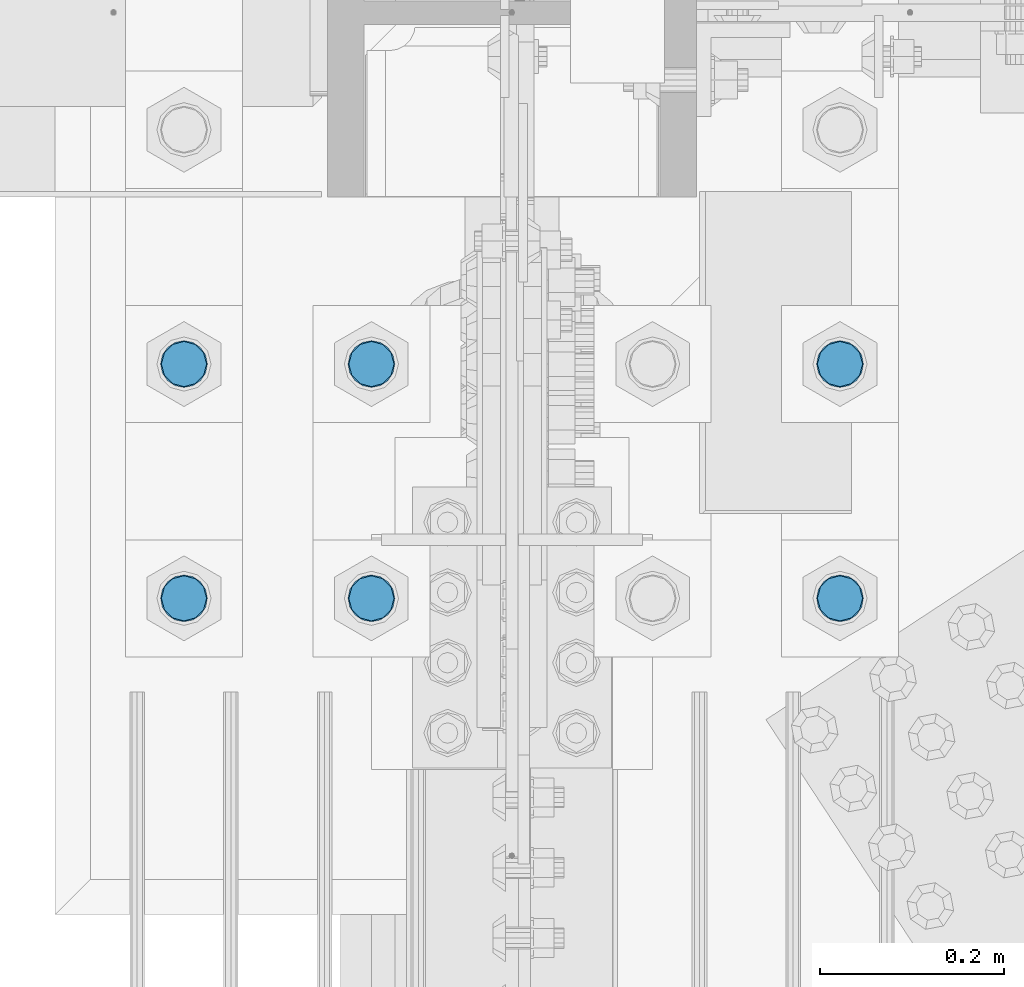
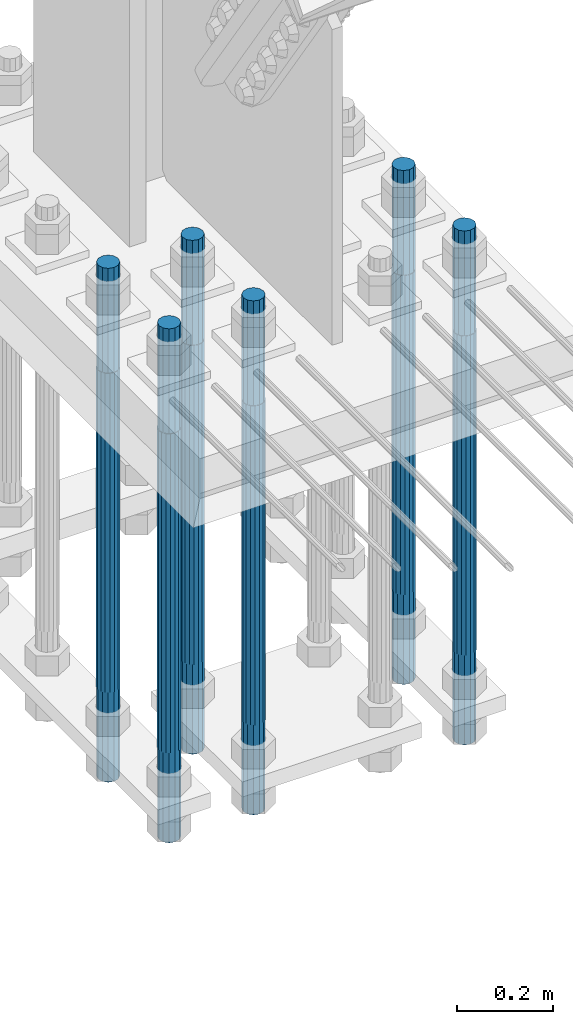
# One storey, part 1329 of 3843: 6 columns, 1 element without a shape of its own.
"""IFC2X3 building model written with IfcOpenShell, lengths in millimetres."""

import ifcopenshell
import ifcopenshell.guid

model = None  # the IFC model being written
_history = None  # IfcOwnerHistory: only IFC2X3 demands one
_inside = {}  # id of a spatial element -> (the spatial element, [elements in it])
_under = {}  # id of a project, library or spatial element -> (it, [spatial elements below it])
_declared = {}  # id of a project -> (the project, [libraries it declares])
_typed = {}  # id of a type object -> (the type object, [elements of that type])
_made_of = {}  # id of a material, layer set ... -> (it, [elements and type objects made of it])


def new_model(schema):
    """Start an empty IFC model of exactly this schema.

    Asked for "IFC4X3", IfcOpenShell would pick the latest addendum, in which some entities
    have other attributes; the version numbers below select the first issue.
    IFC2X3 requires an IfcOwnerHistory on every rooted entity: one is made here for all.
    """
    global model, _history
    if schema == "IFC4X3":
        model = ifcopenshell.file(schema_version=(4, 3, 0, 0))
    else:
        model = ifcopenshell.file(schema=schema)
    _inside.clear()
    _under.clear()
    _declared.clear()
    _typed.clear()
    _made_of.clear()
    _history = None
    if model.schema == "IFC2X3":
        org = make("IfcOrganization", Name="unknown")
        user = make(
            "IfcPersonAndOrganization",
            ThePerson=make("IfcPerson", FamilyName="unknown"),
            TheOrganization=org,
        )
        app = make(
            "IfcApplication",
            ApplicationDeveloper=org,
            Version="unknown",
            ApplicationFullName="unknown",
            ApplicationIdentifier="unknown",
        )
        _history = make(
            "IfcOwnerHistory",
            OwningUser=user,
            OwningApplication=app,
            ChangeAction="ADDED",
            CreationDate=0,
        )
    return model


def make(cls, **values):
    """One entity of the class cls with the attributes given. An attribute that is None is left unset."""
    return model.create_entity(
        cls, **{name: value for name, value in values.items() if value is not None}
    )


def rooted(cls, **values):
    """An entity with a GlobalId (a new one), such as an element, a storey or a relation."""
    return make(cls, GlobalId=ifcopenshell.guid.new(), OwnerHistory=_history, **values)


def si_unit(unit_type, name, prefix=None):
    """IfcSIUnit, for example si_unit("LENGTHUNIT", "METRE", prefix="MILLI")."""
    return make("IfcSIUnit", UnitType=unit_type, Prefix=prefix, Name=name)


def assignment(units):
    """IfcUnitAssignment: the units of a project."""
    return None if units is None else make("IfcUnitAssignment", Units=units)


def point(xyz):
    """IfcCartesianPoint."""
    return None if xyz is None else make("IfcCartesianPoint", Coordinates=xyz)


def direction(xyz):
    """IfcDirection."""
    return None if xyz is None else make("IfcDirection", DirectionRatios=xyz)


def frame(location, z_axis=None, x_axis=None):
    """IfcAxis2Placement3D, a coordinate frame: its origin and axes. An axis left out is left unset."""
    return make(
        "IfcAxis2Placement3D",
        Location=point(location),
        Axis=direction(z_axis),
        RefDirection=direction(x_axis),
    )


def origin_with_axes():
    """The frame at (0, 0, 0) with the z axis (0, 0, 1) and the x axis (1, 0, 0) written out."""
    return frame((0.0, 0.0, 0.0), z_axis=(0.0, 0.0, 1.0), x_axis=(1.0, 0.0, 0.0))


def place(relative_to, where):
    """IfcLocalPlacement: puts the frame where relative to a parent placement (None: the world)."""
    return make(
        "IfcLocalPlacement", PlacementRelTo=relative_to, RelativePlacement=where
    )


def context(
    kind, dimensions, precision=None, world=None, true_north=None, identifier=None
):
    """IfcGeometricRepresentationContext, for example the 3D "Model" context."""
    return make(
        "IfcGeometricRepresentationContext",
        ContextIdentifier=identifier,
        ContextType=kind,
        CoordinateSpaceDimension=dimensions,
        Precision=precision,
        WorldCoordinateSystem=world,
        TrueNorth=true_north,
    )


def subcontext(parent, identifier, kind, view, scale=None):
    """IfcGeometricRepresentationSubContext, for example "Body" below "Model"."""
    return make(
        "IfcGeometricRepresentationSubContext",
        ContextIdentifier=identifier,
        ContextType=kind,
        ParentContext=parent,
        TargetScale=scale,
        TargetView=view,
    )


def project(units=None, contexts=None):
    """IfcProject with its units and contexts."""
    return rooted(
        "IfcProject",
        Name="project",
        RepresentationContexts=contexts,
        UnitsInContext=assignment(units),
    )


def spatial(cls, under=None, at=None, **own):
    """A site, building, storey or space (cls), placed at a placement, below another one or the project."""
    s = rooted(cls, ObjectPlacement=at, **own)
    if under is not None:
        _under.setdefault(under.id(), (under, []))[1].append(s)
    return s


def faces_of(points, faces, orient=None, outer=None):
    """IfcFace entities. A face is a list of loops; a loop is a list of indices into points, from 0.

    orient and outer hold one flag for each loop. By default every Orientation is true, the
    first loop of a face is its IfcFaceOuterBound and the others are IfcFaceBound.
    """
    made = []
    for i, loops in enumerate(faces):
        bounds = []
        for j, loop in enumerate(loops):
            is_outer = j == 0 if outer is None else outer[i][j]
            bounds.append(
                make(
                    "IfcFaceOuterBound" if is_outer else "IfcFaceBound",
                    Bound=make("IfcPolyLoop", Polygon=[points[k] for k in loop]),
                    Orientation=True if orient is None else orient[i][j],
                )
            )
        made.append(make("IfcFace", Bounds=bounds))
    return made


def faceted_brep(points, faces, orient=None, outer=None, voids=None):
    """IfcFacetedBrep: a solid bounded by flat faces; with voids (closed shells), ...WithVoids."""
    shared = [point(p) for p in points]
    hull = make("IfcClosedShell", CfsFaces=faces_of(shared, faces, orient, outer))
    if voids is None:
        return make("IfcFacetedBrep", Outer=hull)
    return make(
        "IfcFacetedBrepWithVoids",
        Outer=hull,
        Voids=[
            make(cls, CfsFaces=faces_of(shared, fs, o, b)) for cls, fs, o, b in voids
        ],
    )


def shape(context_of_items, identifier, shape_type, items):
    """IfcShapeRepresentation: the items that make up one representation, for example the "Body"."""
    return make(
        "IfcShapeRepresentation",
        ContextOfItems=context_of_items,
        RepresentationIdentifier=identifier,
        RepresentationType=shape_type,
        Items=items,
    )


def material(Name=None, Category=None):
    """IfcMaterial."""
    return make("IfcMaterial", Name=Name, Category=Category)


def made_of(thing, what):
    """Note that an element or type object is made of a material, layer set ...; save() writes the relation."""
    if what is not None:
        _made_of.setdefault(what.id(), (what, []))[1].append(thing)
    return thing


def type_object(cls, material=None, **own):
    """A type object (cls), such as IfcWallType, which elements share."""
    return made_of(rooted(cls, **own), material)


def element(
    cls,
    number,
    at=None,
    inside=None,
    cuts=None,
    type_object=None,
    material=None,
    context=None,
    identifier="Body",
    shape_type=None,
    held_by="IfcProductDefinitionShape",
    body=None,
    shapes=None,
    **own,
):
    """One element of the class cls, such as IfcWall. Its Tag is "e" and its number.

    at: its placement. inside: the storey or other place that contains it. cuts: it is an
    opening in that element (IfcRelVoidsElement). A single representation is given by context,
    identifier, shape_type and body (its items); several are given by shapes. held_by: the class
    of the entity that holds the representations. save() writes the other relations.
    """
    e = rooted(cls, Tag="e%d" % number, ObjectPlacement=at, **own)
    if body is not None:
        shapes = [shape(context, identifier, shape_type, body)]
    if shapes is not None:
        e.Representation = make(held_by, Representations=shapes)
    if inside is not None:
        _inside.setdefault(inside.id(), (inside, []))[1].append(e)
    if cuts is not None:
        rooted(
            "IfcRelVoidsElement", RelatingBuildingElement=cuts, RelatedOpeningElement=e
        )
    if type_object is not None:
        _typed.setdefault(type_object.id(), (type_object, []))[1].append(e)
    return made_of(e, material)


def aggregate(whole, parts):
    """IfcRelAggregates: a whole, such as a stair, and the parts it consists of."""
    return rooted("IfcRelAggregates", RelatingObject=whole, RelatedObjects=parts)


def save(model, path):
    """Write the relations noted so far, then the file.

    IfcRelAggregates (storeys below a building ...), IfcRelContainedInSpatialStructure (elements
    in a storey), IfcRelDefinesByType, IfcRelAssociatesMaterial and IfcRelDeclares: one each for
    every whole, place, type object, material and project.
    """
    for whole, parts in _under.values():
        aggregate(whole, parts)
    for where, things in _inside.values():
        rooted(
            "IfcRelContainedInSpatialStructure",
            RelatedElements=things,
            RelatingStructure=where,
        )
    for kind, things in _typed.values():
        rooted("IfcRelDefinesByType", RelatedObjects=things, RelatingType=kind)
    for what, things in _made_of.values():
        rooted("IfcRelAssociatesMaterial", RelatedObjects=things, RelatingMaterial=what)
    for by, libraries in _declared.values():
        rooted("IfcRelDeclares", RelatingContext=by, RelatedDefinitions=libraries)
    model.write(path)


model = new_model("IFC2X3")

# Units and contexts
model_context = context("Model", 3, precision=1e-05, world=origin_with_axes())
body_context = subcontext(model_context, "Body", "Model", "MODEL_VIEW")
ifc_project = project(units=[si_unit("LENGTHUNIT", "METRE", prefix="MILLI"), si_unit("AREAUNIT", "SQUARE_METRE"), si_unit("VOLUMEUNIT", "CUBIC_METRE"), si_unit("MASSUNIT", "GRAM", prefix="KILO"), si_unit("TIMEUNIT", "SECOND"), si_unit("PLANEANGLEUNIT", "RADIAN"), si_unit("SOLIDANGLEUNIT", "STERADIAN"), si_unit("THERMODYNAMICTEMPERATUREUNIT", "DEGREE_CELSIUS"), si_unit("LUMINOUSINTENSITYUNIT", "LUMEN")], contexts=[model_context])

# Site, building, storey
site_placement = place(None, origin_with_axes())
site = spatial("IfcSite", under=ifc_project, at=site_placement, CompositionType="ELEMENT")
building_placement = place(site_placement, origin_with_axes())
building = spatial("IfcBuilding", under=site, at=building_placement, Name="Undefined", CompositionType="ELEMENT")
storey_placement = place(building_placement, origin_with_axes())
storey = spatial("IfcBuildingStorey", under=building, at=storey_placement, Name="Undefined", CompositionType="ELEMENT", Elevation=0.0)

# Assembly, columns
assembly_placement = place(storey_placement, origin_with_axes())
assembly = element("IfcElementAssembly", 1, at=assembly_placement, inside=storey, Name="TEMPLATE", AssemblyPlace="NOTDEFINED", PredefinedType="RIGID_FRAME")
ifc_material = material(Name="Undefined/F1554-GR.55")
column_type = type_object("IfcColumnType", PredefinedType="NOTDEFINED")
column_1_placement = place(assembly_placement, frame((36931.6, 58280.3, 30022.8), z_axis=(1.0, 0.0, 0.0), x_axis=(0.0, 0.0, -1.0)))
column_1 = element("IfcColumn", 2, at=column_1_placement, type_object=column_type, material=ifc_material, Name="ANCHOR_ROD", context=body_context, shape_type="Brep", body=[
    faceted_brep([(-266.700000000001, -21.2176223927236, 12.25), (-266.700000000001, -12.25, 21.2176223927163), (-266.700000000001, 0.0, 24.5), (-266.700000000001, 12.25, 21.2176223927163), (-266.700000000001, 21.2176223927236, 12.25), (-266.700000000001, 24.5, 0.0), (-266.700000000001, 21.2176223927236, -12.25), (-266.700000000001, 12.25, -21.2176223927163), (-266.700000000001, 0.0, -24.5), (-266.700000000001, -12.25, -21.2176223927163), (-266.700000000001, -21.2176223927236, -12.25), (-266.700000000001, -24.5, 0.0), (0.0, 24.5000000000146, 0.0), (0.0, 21.2176223927381, -12.25), (0.0, 12.2500000000146, -21.2176223927163), (0.0, 1.45519152283669e-11, -24.5), (0.0, -12.2499999999854, -21.2176223927163), (0.0, -21.217622392709, -12.25), (0.0, -24.4999999999854, 0.0), (0.0, -21.217622392709, 12.25), (0.0, -12.2499999999854, 21.2176223927163), (0.0, 1.45519152283669e-11, 24.5), (0.0, 12.2500000000146, 21.2176223927163), (0.0, 21.2176223927381, 12.25), (0.0, -23.4665401257807, 9.72015918207035), (0.0, -17.9605122421344, 17.9605122421417), (0.0, -9.72015918207762, 23.466540125788), (0.0, 0.0, 25.4000000000015), (0.0, 9.72015918207762, 23.466540125788), (0.0, 17.9605122421344, 17.9605122421417), (0.0, 23.4665401257807, 9.72015918207035), (0.0, 25.3999996185303, 0.0), (0.0, 23.4665401257807, -9.72015918207035), (0.0, 17.9605122421344, -17.9605122421417), (0.0, 9.72015918207762, -23.466540125788), (0.0, 0.0, -25.4000000000015), (0.0, -9.72015918207762, -23.466540125788), (0.0, -17.9605122421344, -17.9605122421417), (0.0, -23.4665401257807, -9.72015918207035), (0.0, -25.3999996185303, 0.0), (812.799999999999, -25.4000000000015, 0.0), (812.799999999999, -23.466540125788, 9.72015918207398), (812.799999999999, -17.9605122421417, 17.9605122421381), (812.799999999999, -9.72015918207035, 23.466540125788), (812.799999999999, 0.0, 25.4000000000015), (812.799999999999, 9.72015918207035, 23.466540125788), (812.799999999999, 17.9605122421417, 17.9605122421381), (812.799999999999, 23.466540125788, 9.72015918207398), (812.799999999999, 25.4000000000015, 0.0), (812.799999999999, 23.466540125788, -9.72015918207398), (812.799999999999, 17.9605122421417, -17.9605122421381), (812.799999999999, 9.72015918207035, -23.466540125788), (812.799999999999, 0.0, -25.4000000000015), (812.799999999999, -9.72015918207035, -23.466540125788), (812.799999999999, -17.9605122421417, -17.9605122421381), (812.799999999999, -23.466540125788, -9.72015918207398), (812.799999999999, -12.25, 21.2176223927199), (812.799999999999, 0.0, 24.5), (812.799999999999, 12.25, 21.2176223927199), (812.799999999999, 21.2176223927163, 12.25), (812.799999999999, 24.5, 0.0), (812.799999999999, 21.2176223927163, -12.25), (812.799999999999, 12.25, -21.2176223927199), (812.799999999999, 0.0, -24.5), (812.799999999999, -12.25, -21.2176223927199), (812.799999999999, -21.2176223927163, -12.25), (812.799999999999, -24.5, 0.0), (812.799999999999, -21.2176223927163, 12.25), (1041.4, -12.25, -21.2176223927199), (1041.4, 0.0, -24.5), (1041.4, 12.25, -21.2176223927199), (1041.4, 21.2176223927163, -12.25), (1041.4, 24.5, 0.0), (1041.4, 21.2176223927163, 12.25), (1041.4, 12.25, 21.2176223927199), (1041.4, 0.0, 24.5), (1041.4, -12.25, 21.2176223927199), (1041.4, -21.2176223927163, 12.25), (1041.4, -24.5, 0.0), (1041.4, -21.2176223927163, -12.25)], [[[0, 1, 2, 3, 4, 5, 6, 7, 8, 9, 10, 11]], [[6, 5, 12, 13]], [[7, 6, 13, 14]], [[8, 7, 14, 15]], [[9, 8, 15, 16]], [[10, 9, 16, 17]], [[11, 10, 17, 18]], [[0, 11, 18, 19]], [[1, 0, 19, 20]], [[2, 1, 20, 21]], [[3, 2, 21, 22]], [[4, 3, 22, 23]], [[5, 4, 23, 12]], [[24, 25, 26, 27, 28, 29, 30, 31, 32, 33, 34, 35, 36, 37, 38, 39], [22, 21, 20, 19, 18, 17, 16, 15, 14, 13, 12, 23]], [[24, 39, 40, 41]], [[25, 24, 41, 42]], [[26, 25, 42, 43]], [[27, 26, 43, 44]], [[28, 27, 44, 45]], [[29, 28, 45, 46]], [[30, 29, 46, 47]], [[31, 30, 47, 48]], [[32, 31, 48, 49]], [[33, 32, 49, 50]], [[34, 33, 50, 51]], [[35, 34, 51, 52]], [[36, 35, 52, 53]], [[37, 36, 53, 54]], [[38, 37, 54, 55]], [[39, 38, 55, 40]], [[54, 53, 52, 51, 50, 49, 48, 47, 46, 45, 44, 43, 42, 41, 40, 55], [56, 57, 58, 59, 60, 61, 62, 63, 64, 65, 66, 67]], [[68, 69, 70, 71, 72, 73, 74, 75, 76, 77, 78, 79]], [[76, 75, 57, 56]], [[77, 76, 56, 67]], [[78, 77, 67, 66]], [[79, 78, 66, 65]], [[68, 79, 65, 64]], [[69, 68, 64, 63]], [[70, 69, 63, 62]], [[71, 70, 62, 61]], [[72, 71, 61, 60]], [[73, 72, 60, 59]], [[74, 73, 59, 58]], [[75, 74, 58, 57]]]),
])
column_2_placement = place(assembly_placement, frame((36931.6, 58534.3, 30022.8), z_axis=(1.0, 0.0, 0.0), x_axis=(0.0, 0.0, -1.0)))
column_2 = element("IfcColumn", 3, at=column_2_placement, type_object=column_type, material=ifc_material, Name="ANCHOR_ROD", context=body_context, shape_type="Brep", body=[
    faceted_brep([(-266.700000000001, -21.2176223927236, 12.25), (-266.700000000001, -12.25, 21.2176223927163), (-266.700000000001, 0.0, 24.5), (-266.700000000001, 12.25, 21.2176223927163), (-266.700000000001, 21.2176223927236, 12.25), (-266.700000000001, 24.5, 0.0), (-266.700000000001, 21.2176223927236, -12.25), (-266.700000000001, 12.25, -21.2176223927163), (-266.700000000001, 0.0, -24.5), (-266.700000000001, -12.25, -21.2176223927163), (-266.700000000001, -21.2176223927236, -12.25), (-266.700000000001, -24.5, 0.0), (0.0, 24.5000000000146, 0.0), (0.0, 21.2176223927381, -12.25), (0.0, 12.2500000000146, -21.2176223927163), (0.0, 1.45519152283669e-11, -24.5), (0.0, -12.2499999999854, -21.2176223927163), (0.0, -21.217622392709, -12.25), (0.0, -24.4999999999854, 0.0), (0.0, -21.217622392709, 12.25), (0.0, -12.2499999999854, 21.2176223927163), (0.0, 1.45519152283669e-11, 24.5), (0.0, 12.2500000000146, 21.2176223927163), (0.0, 21.2176223927381, 12.25), (0.0, -23.4665401257807, 9.72015918207035), (0.0, -17.9605122421344, 17.9605122421417), (0.0, -9.72015918207762, 23.466540125788), (0.0, 0.0, 25.4000000000015), (0.0, 9.72015918207762, 23.466540125788), (0.0, 17.9605122421344, 17.9605122421417), (0.0, 23.4665401257807, 9.72015918207035), (0.0, 25.3999996185303, 0.0), (0.0, 23.4665401257807, -9.72015918207035), (0.0, 17.9605122421344, -17.9605122421417), (0.0, 9.72015918207762, -23.466540125788), (0.0, 0.0, -25.4000000000015), (0.0, -9.72015918207762, -23.466540125788), (0.0, -17.9605122421344, -17.9605122421417), (0.0, -23.4665401257807, -9.72015918207035), (0.0, -25.3999996185303, 0.0), (812.799999999999, -25.4000000000015, 0.0), (812.799999999999, -23.466540125788, 9.72015918207398), (812.799999999999, -17.9605122421417, 17.9605122421381), (812.799999999999, -9.72015918207035, 23.466540125788), (812.799999999999, 0.0, 25.4000000000015), (812.799999999999, 9.72015918207035, 23.466540125788), (812.799999999999, 17.9605122421417, 17.9605122421381), (812.799999999999, 23.466540125788, 9.72015918207398), (812.799999999999, 25.4000000000015, 0.0), (812.799999999999, 23.466540125788, -9.72015918207398), (812.799999999999, 17.9605122421417, -17.9605122421381), (812.799999999999, 9.72015918207035, -23.466540125788), (812.799999999999, 0.0, -25.4000000000015), (812.799999999999, -9.72015918207035, -23.466540125788), (812.799999999999, -17.9605122421417, -17.9605122421381), (812.799999999999, -23.466540125788, -9.72015918207398), (812.799999999999, -12.25, 21.2176223927199), (812.799999999999, 0.0, 24.5), (812.799999999999, 12.25, 21.2176223927199), (812.799999999999, 21.2176223927163, 12.25), (812.799999999999, 24.5, 0.0), (812.799999999999, 21.2176223927163, -12.25), (812.799999999999, 12.25, -21.2176223927199), (812.799999999999, 0.0, -24.5), (812.799999999999, -12.25, -21.2176223927199), (812.799999999999, -21.2176223927163, -12.25), (812.799999999999, -24.5, 0.0), (812.799999999999, -21.2176223927163, 12.25), (1041.4, -12.25, -21.2176223927199), (1041.4, 0.0, -24.5), (1041.4, 12.25, -21.2176223927199), (1041.4, 21.2176223927163, -12.25), (1041.4, 24.5, 0.0), (1041.4, 21.2176223927163, 12.25), (1041.4, 12.25, 21.2176223927199), (1041.4, 0.0, 24.5), (1041.4, -12.25, 21.2176223927199), (1041.4, -21.2176223927163, 12.25), (1041.4, -24.5, 0.0), (1041.4, -21.2176223927163, -12.25)], [[[0, 1, 2, 3, 4, 5, 6, 7, 8, 9, 10, 11]], [[6, 5, 12, 13]], [[7, 6, 13, 14]], [[8, 7, 14, 15]], [[9, 8, 15, 16]], [[10, 9, 16, 17]], [[11, 10, 17, 18]], [[0, 11, 18, 19]], [[1, 0, 19, 20]], [[2, 1, 20, 21]], [[3, 2, 21, 22]], [[4, 3, 22, 23]], [[5, 4, 23, 12]], [[24, 25, 26, 27, 28, 29, 30, 31, 32, 33, 34, 35, 36, 37, 38, 39], [22, 21, 20, 19, 18, 17, 16, 15, 14, 13, 12, 23]], [[24, 39, 40, 41]], [[25, 24, 41, 42]], [[26, 25, 42, 43]], [[27, 26, 43, 44]], [[28, 27, 44, 45]], [[29, 28, 45, 46]], [[30, 29, 46, 47]], [[31, 30, 47, 48]], [[32, 31, 48, 49]], [[33, 32, 49, 50]], [[34, 33, 50, 51]], [[35, 34, 51, 52]], [[36, 35, 52, 53]], [[37, 36, 53, 54]], [[38, 37, 54, 55]], [[39, 38, 55, 40]], [[54, 53, 52, 51, 50, 49, 48, 47, 46, 45, 44, 43, 42, 41, 40, 55], [56, 57, 58, 59, 60, 61, 62, 63, 64, 65, 66, 67]], [[68, 69, 70, 71, 72, 73, 74, 75, 76, 77, 78, 79]], [[76, 75, 57, 56]], [[77, 76, 56, 67]], [[78, 77, 67, 66]], [[79, 78, 66, 65]], [[68, 79, 65, 64]], [[69, 68, 64, 63]], [[70, 69, 63, 62]], [[71, 70, 62, 61]], [[72, 71, 61, 60]], [[73, 72, 60, 59]], [[74, 73, 59, 58]], [[75, 74, 58, 57]]]),
])
column_3_placement = place(assembly_placement, frame((36423.6, 58280.3, 30022.8), z_axis=(1.0, 0.0, 0.0), x_axis=(0.0, 0.0, -1.0)))
column_3 = element("IfcColumn", 4, at=column_3_placement, type_object=column_type, material=ifc_material, Name="ANCHOR_ROD", context=body_context, shape_type="Brep", body=[
    faceted_brep([(-266.700000000001, -21.2176223927236, 12.25), (-266.700000000001, -12.25, 21.2176223927163), (-266.700000000001, 0.0, 24.5), (-266.700000000001, 12.25, 21.2176223927163), (-266.700000000001, 21.2176223927236, 12.25), (-266.700000000001, 24.5, 0.0), (-266.700000000001, 21.2176223927236, -12.25), (-266.700000000001, 12.25, -21.2176223927163), (-266.700000000001, 0.0, -24.5), (-266.700000000001, -12.25, -21.2176223927163), (-266.700000000001, -21.2176223927236, -12.25), (-266.700000000001, -24.5, 0.0), (0.0, 24.5000000000146, 0.0), (0.0, 21.2176223927381, -12.25), (0.0, 12.2500000000146, -21.2176223927163), (0.0, 1.45519152283669e-11, -24.5), (0.0, -12.2499999999854, -21.2176223927163), (0.0, -21.217622392709, -12.25), (0.0, -24.4999999999854, 0.0), (0.0, -21.217622392709, 12.25), (0.0, -12.2499999999854, 21.2176223927163), (0.0, 1.45519152283669e-11, 24.5), (0.0, 12.2500000000146, 21.2176223927163), (0.0, 21.2176223927381, 12.25), (0.0, -23.4665401257807, 9.72015918207035), (0.0, -17.9605122421344, 17.9605122421417), (0.0, -9.72015918207762, 23.466540125788), (0.0, 0.0, 25.4000000000015), (0.0, 9.72015918207762, 23.466540125788), (0.0, 17.9605122421344, 17.9605122421417), (0.0, 23.4665401257807, 9.72015918207035), (0.0, 25.3999996185303, 0.0), (0.0, 23.4665401257807, -9.72015918207035), (0.0, 17.9605122421344, -17.9605122421417), (0.0, 9.72015918207762, -23.466540125788), (0.0, 0.0, -25.4000000000015), (0.0, -9.72015918207762, -23.466540125788), (0.0, -17.9605122421344, -17.9605122421417), (0.0, -23.4665401257807, -9.72015918207035), (0.0, -25.3999996185303, 0.0), (812.799999999999, -25.4000000000015, 0.0), (812.799999999999, -23.466540125788, 9.72015918207398), (812.799999999999, -17.9605122421417, 17.9605122421381), (812.799999999999, -9.72015918207035, 23.466540125788), (812.799999999999, 0.0, 25.4000000000015), (812.799999999999, 9.72015918207035, 23.466540125788), (812.799999999999, 17.9605122421417, 17.9605122421381), (812.799999999999, 23.466540125788, 9.72015918207398), (812.799999999999, 25.4000000000015, 0.0), (812.799999999999, 23.466540125788, -9.72015918207398), (812.799999999999, 17.9605122421417, -17.9605122421381), (812.799999999999, 9.72015918207035, -23.466540125788), (812.799999999999, 0.0, -25.4000000000015), (812.799999999999, -9.72015918207035, -23.466540125788), (812.799999999999, -17.9605122421417, -17.9605122421381), (812.799999999999, -23.466540125788, -9.72015918207398), (812.799999999999, -12.25, 21.2176223927199), (812.799999999999, 0.0, 24.5), (812.799999999999, 12.25, 21.2176223927199), (812.799999999999, 21.2176223927163, 12.25), (812.799999999999, 24.5, 0.0), (812.799999999999, 21.2176223927163, -12.25), (812.799999999999, 12.25, -21.2176223927199), (812.799999999999, 0.0, -24.5), (812.799999999999, -12.25, -21.2176223927199), (812.799999999999, -21.2176223927163, -12.25), (812.799999999999, -24.5, 0.0), (812.799999999999, -21.2176223927163, 12.25), (1041.4, -12.25, -21.2176223927199), (1041.4, 0.0, -24.5), (1041.4, 12.25, -21.2176223927199), (1041.4, 21.2176223927163, -12.25), (1041.4, 24.5, 0.0), (1041.4, 21.2176223927163, 12.25), (1041.4, 12.25, 21.2176223927199), (1041.4, 0.0, 24.5), (1041.4, -12.25, 21.2176223927199), (1041.4, -21.2176223927163, 12.25), (1041.4, -24.5, 0.0), (1041.4, -21.2176223927163, -12.25)], [[[0, 1, 2, 3, 4, 5, 6, 7, 8, 9, 10, 11]], [[6, 5, 12, 13]], [[7, 6, 13, 14]], [[8, 7, 14, 15]], [[9, 8, 15, 16]], [[10, 9, 16, 17]], [[11, 10, 17, 18]], [[0, 11, 18, 19]], [[1, 0, 19, 20]], [[2, 1, 20, 21]], [[3, 2, 21, 22]], [[4, 3, 22, 23]], [[5, 4, 23, 12]], [[24, 25, 26, 27, 28, 29, 30, 31, 32, 33, 34, 35, 36, 37, 38, 39], [22, 21, 20, 19, 18, 17, 16, 15, 14, 13, 12, 23]], [[24, 39, 40, 41]], [[25, 24, 41, 42]], [[26, 25, 42, 43]], [[27, 26, 43, 44]], [[28, 27, 44, 45]], [[29, 28, 45, 46]], [[30, 29, 46, 47]], [[31, 30, 47, 48]], [[32, 31, 48, 49]], [[33, 32, 49, 50]], [[34, 33, 50, 51]], [[35, 34, 51, 52]], [[36, 35, 52, 53]], [[37, 36, 53, 54]], [[38, 37, 54, 55]], [[39, 38, 55, 40]], [[54, 53, 52, 51, 50, 49, 48, 47, 46, 45, 44, 43, 42, 41, 40, 55], [56, 57, 58, 59, 60, 61, 62, 63, 64, 65, 66, 67]], [[68, 69, 70, 71, 72, 73, 74, 75, 76, 77, 78, 79]], [[76, 75, 57, 56]], [[77, 76, 56, 67]], [[78, 77, 67, 66]], [[79, 78, 66, 65]], [[68, 79, 65, 64]], [[69, 68, 64, 63]], [[70, 69, 63, 62]], [[71, 70, 62, 61]], [[72, 71, 61, 60]], [[73, 72, 60, 59]], [[74, 73, 59, 58]], [[75, 74, 58, 57]]]),
])
column_4_placement = place(assembly_placement, frame((36423.6, 58534.3, 30022.8), z_axis=(1.0, 0.0, 0.0), x_axis=(0.0, 0.0, -1.0)))
column_4 = element("IfcColumn", 5, at=column_4_placement, type_object=column_type, material=ifc_material, Name="ANCHOR_ROD", context=body_context, shape_type="Brep", body=[
    faceted_brep([(-266.700000000001, -21.2176223927236, 12.25), (-266.700000000001, -12.25, 21.2176223927163), (-266.700000000001, 0.0, 24.5), (-266.700000000001, 12.25, 21.2176223927163), (-266.700000000001, 21.2176223927236, 12.25), (-266.700000000001, 24.5, 0.0), (-266.700000000001, 21.2176223927236, -12.25), (-266.700000000001, 12.25, -21.2176223927163), (-266.700000000001, 0.0, -24.5), (-266.700000000001, -12.25, -21.2176223927163), (-266.700000000001, -21.2176223927236, -12.25), (-266.700000000001, -24.5, 0.0), (0.0, 24.5000000000146, 0.0), (0.0, 21.2176223927381, -12.25), (0.0, 12.2500000000146, -21.2176223927163), (0.0, 1.45519152283669e-11, -24.5), (0.0, -12.2499999999854, -21.2176223927163), (0.0, -21.217622392709, -12.25), (0.0, -24.4999999999854, 0.0), (0.0, -21.217622392709, 12.25), (0.0, -12.2499999999854, 21.2176223927163), (0.0, 1.45519152283669e-11, 24.5), (0.0, 12.2500000000146, 21.2176223927163), (0.0, 21.2176223927381, 12.25), (0.0, -23.4665401257807, 9.72015918207035), (0.0, -17.9605122421344, 17.9605122421417), (0.0, -9.72015918207762, 23.466540125788), (0.0, 0.0, 25.4000000000015), (0.0, 9.72015918207762, 23.466540125788), (0.0, 17.9605122421344, 17.9605122421417), (0.0, 23.4665401257807, 9.72015918207035), (0.0, 25.3999996185303, 0.0), (0.0, 23.4665401257807, -9.72015918207035), (0.0, 17.9605122421344, -17.9605122421417), (0.0, 9.72015918207762, -23.466540125788), (0.0, 0.0, -25.4000000000015), (0.0, -9.72015918207762, -23.466540125788), (0.0, -17.9605122421344, -17.9605122421417), (0.0, -23.4665401257807, -9.72015918207035), (0.0, -25.3999996185303, 0.0), (812.799999999999, -25.4000000000015, 0.0), (812.799999999999, -23.466540125788, 9.72015918207398), (812.799999999999, -17.9605122421417, 17.9605122421381), (812.799999999999, -9.72015918207035, 23.466540125788), (812.799999999999, 0.0, 25.4000000000015), (812.799999999999, 9.72015918207035, 23.466540125788), (812.799999999999, 17.9605122421417, 17.9605122421381), (812.799999999999, 23.466540125788, 9.72015918207398), (812.799999999999, 25.4000000000015, 0.0), (812.799999999999, 23.466540125788, -9.72015918207398), (812.799999999999, 17.9605122421417, -17.9605122421381), (812.799999999999, 9.72015918207035, -23.466540125788), (812.799999999999, 0.0, -25.4000000000015), (812.799999999999, -9.72015918207035, -23.466540125788), (812.799999999999, -17.9605122421417, -17.9605122421381), (812.799999999999, -23.466540125788, -9.72015918207398), (812.799999999999, -12.25, 21.2176223927199), (812.799999999999, 0.0, 24.5), (812.799999999999, 12.25, 21.2176223927199), (812.799999999999, 21.2176223927163, 12.25), (812.799999999999, 24.5, 0.0), (812.799999999999, 21.2176223927163, -12.25), (812.799999999999, 12.25, -21.2176223927199), (812.799999999999, 0.0, -24.5), (812.799999999999, -12.25, -21.2176223927199), (812.799999999999, -21.2176223927163, -12.25), (812.799999999999, -24.5, 0.0), (812.799999999999, -21.2176223927163, 12.25), (1041.4, -12.25, -21.2176223927199), (1041.4, 0.0, -24.5), (1041.4, 12.25, -21.2176223927199), (1041.4, 21.2176223927163, -12.25), (1041.4, 24.5, 0.0), (1041.4, 21.2176223927163, 12.25), (1041.4, 12.25, 21.2176223927199), (1041.4, 0.0, 24.5), (1041.4, -12.25, 21.2176223927199), (1041.4, -21.2176223927163, 12.25), (1041.4, -24.5, 0.0), (1041.4, -21.2176223927163, -12.25)], [[[0, 1, 2, 3, 4, 5, 6, 7, 8, 9, 10, 11]], [[6, 5, 12, 13]], [[7, 6, 13, 14]], [[8, 7, 14, 15]], [[9, 8, 15, 16]], [[10, 9, 16, 17]], [[11, 10, 17, 18]], [[0, 11, 18, 19]], [[1, 0, 19, 20]], [[2, 1, 20, 21]], [[3, 2, 21, 22]], [[4, 3, 22, 23]], [[5, 4, 23, 12]], [[24, 25, 26, 27, 28, 29, 30, 31, 32, 33, 34, 35, 36, 37, 38, 39], [22, 21, 20, 19, 18, 17, 16, 15, 14, 13, 12, 23]], [[24, 39, 40, 41]], [[25, 24, 41, 42]], [[26, 25, 42, 43]], [[27, 26, 43, 44]], [[28, 27, 44, 45]], [[29, 28, 45, 46]], [[30, 29, 46, 47]], [[31, 30, 47, 48]], [[32, 31, 48, 49]], [[33, 32, 49, 50]], [[34, 33, 50, 51]], [[35, 34, 51, 52]], [[36, 35, 52, 53]], [[37, 36, 53, 54]], [[38, 37, 54, 55]], [[39, 38, 55, 40]], [[54, 53, 52, 51, 50, 49, 48, 47, 46, 45, 44, 43, 42, 41, 40, 55], [56, 57, 58, 59, 60, 61, 62, 63, 64, 65, 66, 67]], [[68, 69, 70, 71, 72, 73, 74, 75, 76, 77, 78, 79]], [[76, 75, 57, 56]], [[77, 76, 56, 67]], [[78, 77, 67, 66]], [[79, 78, 66, 65]], [[68, 79, 65, 64]], [[69, 68, 64, 63]], [[70, 69, 63, 62]], [[71, 70, 62, 61]], [[72, 71, 61, 60]], [[73, 72, 60, 59]], [[74, 73, 59, 58]], [[75, 74, 58, 57]]]),
])
column_5_placement = place(assembly_placement, frame((36220.4, 58280.3, 30022.8), z_axis=(1.0, 0.0, 0.0), x_axis=(0.0, 0.0, -1.0)))
column_5 = element("IfcColumn", 6, at=column_5_placement, type_object=column_type, material=ifc_material, Name="ANCHOR_ROD", context=body_context, shape_type="Brep", body=[
    faceted_brep([(-266.700000000001, -21.2176223927236, 12.25), (-266.700000000001, -12.25, 21.2176223927163), (-266.700000000001, 0.0, 24.5), (-266.700000000001, 12.25, 21.2176223927163), (-266.700000000001, 21.2176223927236, 12.25), (-266.700000000001, 24.5, 0.0), (-266.700000000001, 21.2176223927236, -12.25), (-266.700000000001, 12.25, -21.2176223927163), (-266.700000000001, 0.0, -24.5), (-266.700000000001, -12.25, -21.2176223927163), (-266.700000000001, -21.2176223927236, -12.25), (-266.700000000001, -24.5, 0.0), (0.0, 24.5000000000146, 0.0), (0.0, 21.2176223927381, -12.25), (0.0, 12.2500000000146, -21.2176223927163), (0.0, 1.45519152283669e-11, -24.5), (0.0, -12.2499999999854, -21.2176223927163), (0.0, -21.217622392709, -12.25), (0.0, -24.4999999999854, 0.0), (0.0, -21.217622392709, 12.25), (0.0, -12.2499999999854, 21.2176223927163), (0.0, 1.45519152283669e-11, 24.5), (0.0, 12.2500000000146, 21.2176223927163), (0.0, 21.2176223927381, 12.25), (0.0, -23.4665401257807, 9.72015918207035), (0.0, -17.9605122421344, 17.9605122421417), (0.0, -9.72015918207762, 23.466540125788), (0.0, 0.0, 25.4000000000015), (0.0, 9.72015918207762, 23.466540125788), (0.0, 17.9605122421344, 17.9605122421417), (0.0, 23.4665401257807, 9.72015918207035), (0.0, 25.3999996185303, 0.0), (0.0, 23.4665401257807, -9.72015918207035), (0.0, 17.9605122421344, -17.9605122421417), (0.0, 9.72015918207762, -23.466540125788), (0.0, 0.0, -25.4000000000015), (0.0, -9.72015918207762, -23.466540125788), (0.0, -17.9605122421344, -17.9605122421417), (0.0, -23.4665401257807, -9.72015918207035), (0.0, -25.3999996185303, 0.0), (812.799999999999, -25.4000000000015, 0.0), (812.799999999999, -23.466540125788, 9.72015918207398), (812.799999999999, -17.9605122421417, 17.9605122421381), (812.799999999999, -9.72015918207035, 23.466540125788), (812.799999999999, 0.0, 25.4000000000015), (812.799999999999, 9.72015918207035, 23.466540125788), (812.799999999999, 17.9605122421417, 17.9605122421381), (812.799999999999, 23.466540125788, 9.72015918207398), (812.799999999999, 25.4000000000015, 0.0), (812.799999999999, 23.466540125788, -9.72015918207398), (812.799999999999, 17.9605122421417, -17.9605122421381), (812.799999999999, 9.72015918207035, -23.466540125788), (812.799999999999, 0.0, -25.4000000000015), (812.799999999999, -9.72015918207035, -23.466540125788), (812.799999999999, -17.9605122421417, -17.9605122421381), (812.799999999999, -23.466540125788, -9.72015918207398), (812.799999999999, -12.25, 21.2176223927199), (812.799999999999, 0.0, 24.5), (812.799999999999, 12.25, 21.2176223927199), (812.799999999999, 21.2176223927163, 12.25), (812.799999999999, 24.5, 0.0), (812.799999999999, 21.2176223927163, -12.25), (812.799999999999, 12.25, -21.2176223927199), (812.799999999999, 0.0, -24.5), (812.799999999999, -12.25, -21.2176223927199), (812.799999999999, -21.2176223927163, -12.25), (812.799999999999, -24.5, 0.0), (812.799999999999, -21.2176223927163, 12.25), (1041.4, -12.25, -21.2176223927199), (1041.4, 0.0, -24.5), (1041.4, 12.25, -21.2176223927199), (1041.4, 21.2176223927163, -12.25), (1041.4, 24.5, 0.0), (1041.4, 21.2176223927163, 12.25), (1041.4, 12.25, 21.2176223927199), (1041.4, 0.0, 24.5), (1041.4, -12.25, 21.2176223927199), (1041.4, -21.2176223927163, 12.25), (1041.4, -24.5, 0.0), (1041.4, -21.2176223927163, -12.25)], [[[0, 1, 2, 3, 4, 5, 6, 7, 8, 9, 10, 11]], [[6, 5, 12, 13]], [[7, 6, 13, 14]], [[8, 7, 14, 15]], [[9, 8, 15, 16]], [[10, 9, 16, 17]], [[11, 10, 17, 18]], [[0, 11, 18, 19]], [[1, 0, 19, 20]], [[2, 1, 20, 21]], [[3, 2, 21, 22]], [[4, 3, 22, 23]], [[5, 4, 23, 12]], [[24, 25, 26, 27, 28, 29, 30, 31, 32, 33, 34, 35, 36, 37, 38, 39], [22, 21, 20, 19, 18, 17, 16, 15, 14, 13, 12, 23]], [[24, 39, 40, 41]], [[25, 24, 41, 42]], [[26, 25, 42, 43]], [[27, 26, 43, 44]], [[28, 27, 44, 45]], [[29, 28, 45, 46]], [[30, 29, 46, 47]], [[31, 30, 47, 48]], [[32, 31, 48, 49]], [[33, 32, 49, 50]], [[34, 33, 50, 51]], [[35, 34, 51, 52]], [[36, 35, 52, 53]], [[37, 36, 53, 54]], [[38, 37, 54, 55]], [[39, 38, 55, 40]], [[54, 53, 52, 51, 50, 49, 48, 47, 46, 45, 44, 43, 42, 41, 40, 55], [56, 57, 58, 59, 60, 61, 62, 63, 64, 65, 66, 67]], [[68, 69, 70, 71, 72, 73, 74, 75, 76, 77, 78, 79]], [[76, 75, 57, 56]], [[77, 76, 56, 67]], [[78, 77, 67, 66]], [[79, 78, 66, 65]], [[68, 79, 65, 64]], [[69, 68, 64, 63]], [[70, 69, 63, 62]], [[71, 70, 62, 61]], [[72, 71, 61, 60]], [[73, 72, 60, 59]], [[74, 73, 59, 58]], [[75, 74, 58, 57]]]),
])
column_6_placement = place(assembly_placement, frame((36220.4, 58534.3, 30022.8), z_axis=(1.0, 0.0, 0.0), x_axis=(0.0, 0.0, -1.0)))
column_6 = element("IfcColumn", 7, at=column_6_placement, type_object=column_type, material=ifc_material, Name="ANCHOR_ROD", context=body_context, shape_type="Brep", body=[
    faceted_brep([(-266.700000000001, -21.2176223927236, 12.25), (-266.700000000001, -12.25, 21.2176223927163), (-266.700000000001, 0.0, 24.5), (-266.700000000001, 12.25, 21.2176223927163), (-266.700000000001, 21.2176223927236, 12.25), (-266.700000000001, 24.5, 0.0), (-266.700000000001, 21.2176223927236, -12.25), (-266.700000000001, 12.25, -21.2176223927163), (-266.700000000001, 0.0, -24.5), (-266.700000000001, -12.25, -21.2176223927163), (-266.700000000001, -21.2176223927236, -12.25), (-266.700000000001, -24.5, 0.0), (0.0, 24.5000000000146, 0.0), (0.0, 21.2176223927381, -12.25), (0.0, 12.2500000000146, -21.2176223927163), (0.0, 1.45519152283669e-11, -24.5), (0.0, -12.2499999999854, -21.2176223927163), (0.0, -21.217622392709, -12.25), (0.0, -24.4999999999854, 0.0), (0.0, -21.217622392709, 12.25), (0.0, -12.2499999999854, 21.2176223927163), (0.0, 1.45519152283669e-11, 24.5), (0.0, 12.2500000000146, 21.2176223927163), (0.0, 21.2176223927381, 12.25), (0.0, -23.4665401257807, 9.72015918207035), (0.0, -17.9605122421344, 17.9605122421417), (0.0, -9.72015918207762, 23.466540125788), (0.0, 0.0, 25.4000000000015), (0.0, 9.72015918207762, 23.466540125788), (0.0, 17.9605122421344, 17.9605122421417), (0.0, 23.4665401257807, 9.72015918207035), (0.0, 25.3999996185303, 0.0), (0.0, 23.4665401257807, -9.72015918207035), (0.0, 17.9605122421344, -17.9605122421417), (0.0, 9.72015918207762, -23.466540125788), (0.0, 0.0, -25.4000000000015), (0.0, -9.72015918207762, -23.466540125788), (0.0, -17.9605122421344, -17.9605122421417), (0.0, -23.4665401257807, -9.72015918207035), (0.0, -25.3999996185303, 0.0), (812.799999999999, -25.4000000000015, 0.0), (812.799999999999, -23.466540125788, 9.72015918207398), (812.799999999999, -17.9605122421417, 17.9605122421381), (812.799999999999, -9.72015918207035, 23.466540125788), (812.799999999999, 0.0, 25.4000000000015), (812.799999999999, 9.72015918207035, 23.466540125788), (812.799999999999, 17.9605122421417, 17.9605122421381), (812.799999999999, 23.466540125788, 9.72015918207398), (812.799999999999, 25.4000000000015, 0.0), (812.799999999999, 23.466540125788, -9.72015918207398), (812.799999999999, 17.9605122421417, -17.9605122421381), (812.799999999999, 9.72015918207035, -23.466540125788), (812.799999999999, 0.0, -25.4000000000015), (812.799999999999, -9.72015918207035, -23.466540125788), (812.799999999999, -17.9605122421417, -17.9605122421381), (812.799999999999, -23.466540125788, -9.72015918207398), (812.799999999999, -12.25, 21.2176223927199), (812.799999999999, 0.0, 24.5), (812.799999999999, 12.25, 21.2176223927199), (812.799999999999, 21.2176223927163, 12.25), (812.799999999999, 24.5, 0.0), (812.799999999999, 21.2176223927163, -12.25), (812.799999999999, 12.25, -21.2176223927199), (812.799999999999, 0.0, -24.5), (812.799999999999, -12.25, -21.2176223927199), (812.799999999999, -21.2176223927163, -12.25), (812.799999999999, -24.5, 0.0), (812.799999999999, -21.2176223927163, 12.25), (1041.4, -12.25, -21.2176223927199), (1041.4, 0.0, -24.5), (1041.4, 12.25, -21.2176223927199), (1041.4, 21.2176223927163, -12.25), (1041.4, 24.5, 0.0), (1041.4, 21.2176223927163, 12.25), (1041.4, 12.25, 21.2176223927199), (1041.4, 0.0, 24.5), (1041.4, -12.25, 21.2176223927199), (1041.4, -21.2176223927163, 12.25), (1041.4, -24.5, 0.0), (1041.4, -21.2176223927163, -12.25)], [[[0, 1, 2, 3, 4, 5, 6, 7, 8, 9, 10, 11]], [[6, 5, 12, 13]], [[7, 6, 13, 14]], [[8, 7, 14, 15]], [[9, 8, 15, 16]], [[10, 9, 16, 17]], [[11, 10, 17, 18]], [[0, 11, 18, 19]], [[1, 0, 19, 20]], [[2, 1, 20, 21]], [[3, 2, 21, 22]], [[4, 3, 22, 23]], [[5, 4, 23, 12]], [[24, 25, 26, 27, 28, 29, 30, 31, 32, 33, 34, 35, 36, 37, 38, 39], [22, 21, 20, 19, 18, 17, 16, 15, 14, 13, 12, 23]], [[24, 39, 40, 41]], [[25, 24, 41, 42]], [[26, 25, 42, 43]], [[27, 26, 43, 44]], [[28, 27, 44, 45]], [[29, 28, 45, 46]], [[30, 29, 46, 47]], [[31, 30, 47, 48]], [[32, 31, 48, 49]], [[33, 32, 49, 50]], [[34, 33, 50, 51]], [[35, 34, 51, 52]], [[36, 35, 52, 53]], [[37, 36, 53, 54]], [[38, 37, 54, 55]], [[39, 38, 55, 40]], [[54, 53, 52, 51, 50, 49, 48, 47, 46, 45, 44, 43, 42, 41, 40, 55], [56, 57, 58, 59, 60, 61, 62, 63, 64, 65, 66, 67]], [[68, 69, 70, 71, 72, 73, 74, 75, 76, 77, 78, 79]], [[76, 75, 57, 56]], [[77, 76, 56, 67]], [[78, 77, 67, 66]], [[79, 78, 66, 65]], [[68, 79, 65, 64]], [[69, 68, 64, 63]], [[70, 69, 63, 62]], [[71, 70, 62, 61]], [[72, 71, 61, 60]], [[73, 72, 60, 59]], [[74, 73, 59, 58]], [[75, 74, 58, 57]]]),
])
aggregate(assembly, [column_1, column_2, column_3, column_4, column_5, column_6])

save(model, "model.ifc")
